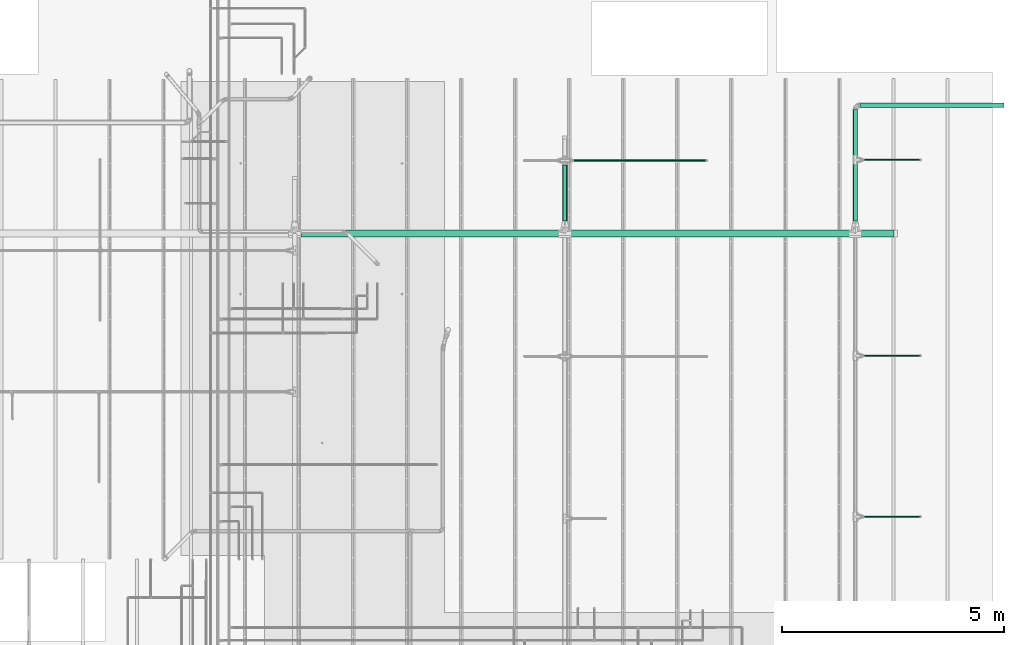
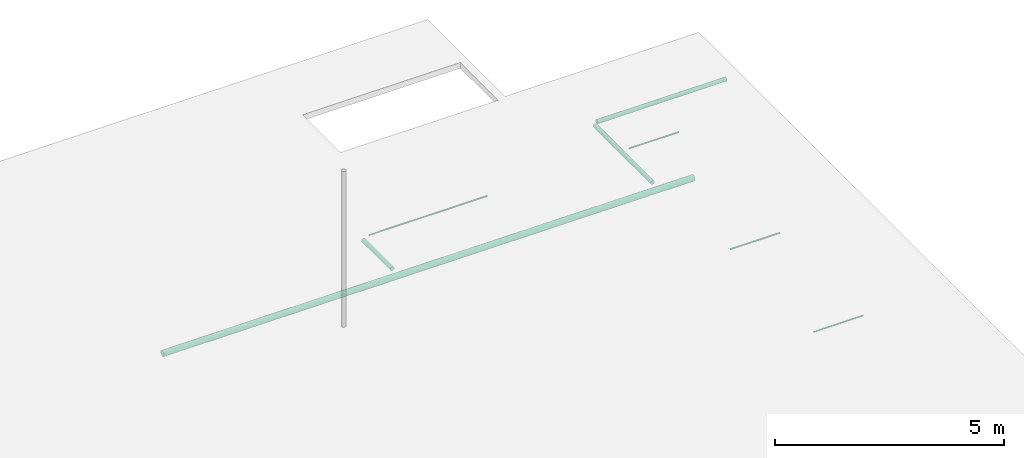
# One storey, part 7 of 173: 8 flow segments.
"""IFC2X3 building model written with IfcOpenShell, lengths in feet."""

from ifc_helpers import new_model, entity, si_unit, converted_unit, derived_unit, direction, frame, origin, origin_2d_with_axis, place, context, subcontext, project, spatial, circle, extrude, source, transform, mapped, type_object, type_shapes, element, save


model = new_model("IFC2X3")

# Units and contexts
model_context = context("Model", 3, precision=0.0001, world=origin(), true_north=direction((6.12303176911189e-17, 1.0)))
body_context = subcontext(model_context, "Body", "Model", "MODEL_VIEW")
ifc_project = project(units=[converted_unit("LENGTHUNIT", "FOOT", entity("IfcRatioMeasure", 0.3048), si_unit("LENGTHUNIT", "METRE"), dimensions=[1, 0, 0, 0, 0, 0, 0]), converted_unit("AREAUNIT", "SQUARE FOOT", entity("IfcRatioMeasure", 0.09290304), si_unit("AREAUNIT", "SQUARE_METRE"), dimensions=[2, 0, 0, 0, 0, 0, 0]), converted_unit("VOLUMEUNIT", "CUBIC FOOT", entity("IfcRatioMeasure", 0.028316846592), si_unit("VOLUMEUNIT", "CUBIC_METRE"), dimensions=[3, 0, 0, 0, 0, 0, 0]), converted_unit("PLANEANGLEUNIT", "DEGREE", entity("IfcRatioMeasure", 0.0174532925199433), si_unit("PLANEANGLEUNIT", "RADIAN"), dimensions=[0, 0, 0, 0, 0, 0, 0]), si_unit("MASSUNIT", "GRAM", prefix="KILO"), derived_unit("MASSDENSITYUNIT", [(si_unit("MASSUNIT", "GRAM", prefix="KILO"), 1), (si_unit("LENGTHUNIT", "METRE"), -3)]), si_unit("TIMEUNIT", "SECOND"), si_unit("FREQUENCYUNIT", "HERTZ"), si_unit("THERMODYNAMICTEMPERATUREUNIT", "DEGREE_CELSIUS"), derived_unit("THERMALTRANSMITTANCEUNIT", [(si_unit("MASSUNIT", "GRAM", prefix="KILO"), 1), (si_unit("THERMODYNAMICTEMPERATUREUNIT", "KELVIN"), -1), (si_unit("TIMEUNIT", "SECOND"), -3)]), derived_unit("VOLUMETRICFLOWRATEUNIT", [(si_unit("LENGTHUNIT", "METRE"), 3), (si_unit("TIMEUNIT", "SECOND"), -1)]), si_unit("ELECTRICCURRENTUNIT", "AMPERE"), si_unit("ELECTRICVOLTAGEUNIT", "VOLT"), si_unit("POWERUNIT", "WATT"), si_unit("FORCEUNIT", "NEWTON"), si_unit("ILLUMINANCEUNIT", "LUX"), si_unit("LUMINOUSFLUXUNIT", "LUMEN"), si_unit("LUMINOUSINTENSITYUNIT", "CANDELA"), derived_unit("USERDEFINED", [(si_unit("MASSUNIT", "GRAM", prefix="KILO"), -1), (si_unit("LENGTHUNIT", "METRE"), -2), (si_unit("TIMEUNIT", "SECOND"), 3), (si_unit("LUMINOUSFLUXUNIT", "LUMEN"), 1)]), derived_unit("LINEARVELOCITYUNIT", [(si_unit("LENGTHUNIT", "METRE"), 1), (si_unit("TIMEUNIT", "SECOND"), -1)]), si_unit("PRESSUREUNIT", "PASCAL"), derived_unit("USERDEFINED", [(si_unit("LENGTHUNIT", "METRE"), -2), (si_unit("MASSUNIT", "GRAM", prefix="KILO"), 1), (si_unit("TIMEUNIT", "SECOND"), -2)])], contexts=[model_context])

# Site, building, storey
site_placement = place(None, origin())
site = spatial("IfcSite", under=ifc_project, at=site_placement, CompositionType="ELEMENT")
building_placement = place(site_placement, origin())
building = spatial("IfcBuilding", under=site, at=building_placement, CompositionType="ELEMENT")
storey_placement = place(building_placement, frame((0.0, 0.0, 8.0)))
storey = spatial("IfcBuildingStorey", under=building, at=storey_placement, Name="REF", CompositionType="ELEMENT", Elevation=8.0)

# Flow segments
pipe_segment_type_1 = type_object("IfcPipeSegmentType", Name="Pipe Types:Standard", PredefinedType="NOTDEFINED")
shared_shape_1 = source(origin(), body_context, "Body", "SweptSolid", [
    extrude(circle(Radius=0.255208333333333, at=origin_2d_with_axis()), frame((3.86549075824204, 42.5032349157208, 10.4173177083333), z_axis=(1.0, 0.0, 0.0), x_axis=(0.0, -1.0, 0.0)), (0.0, 0.0, 1.0), 43.8717276472823),
])
type_shapes(pipe_segment_type_1, [shared_shape_1])
flow_segment_1_placement = place(storey_placement, frame((0.0, 0.0, -8.0)))
element("IfcFlowSegment", 1, at=flow_segment_1_placement, inside=storey, type_object=pipe_segment_type_1, Name="Pipe Types:Standard:Standard : Pipe Types:Standard", ObjectType="Standard : Pipe Types:Standard", context=body_context, shape_type="MappedRepresentation", body=[
    mapped(shared_shape_1, transform((0.0, 0.0, 0.0), scale=1.0)),
])
pipe_segment_type_2 = type_object("IfcPipeSegmentType", Name="Pipe Types:Standard", PredefinedType="NOTDEFINED")
shared_shape_2 = source(origin(), body_context, "Body", "SweptSolid", [
    extrude(circle(Radius=0.171875, at=origin_2d_with_axis()), frame((44.8963306532552, 43.4317126060094, 10.4173177083333), z_axis=(0.0, 1.0, 0.0), x_axis=(1.0, 0.0, 0.0)), (0.0, 0.0, 1.0), 8.23687664041991),
])
type_shapes(pipe_segment_type_2, [shared_shape_2])
flow_segment_2_placement = place(storey_placement, frame((0.0, 0.0, -8.0)))
element("IfcFlowSegment", 2, at=flow_segment_2_placement, inside=storey, type_object=pipe_segment_type_2, Name="Pipe Types:Standard:Standard : Pipe Types:Standard", ObjectType="Standard : Pipe Types:Standard", context=body_context, shape_type="MappedRepresentation", body=[
    mapped(shared_shape_2, transform((0.0, 0.0, 0.0), scale=1.0)),
])
pipe_segment_type_3 = type_object("IfcPipeSegmentType", Name="Pipe Types:Standard", PredefinedType="NOTDEFINED")
shared_shape_3 = source(origin(), body_context, "Body", "SweptSolid", [
    extrude(circle(Radius=0.171875, at=origin_2d_with_axis()), frame((45.2309763225465, 52.0032349157206, 10.4173177083333), z_axis=(1.0, 0.0, 0.0), x_axis=(0.0, -1.0, 0.0)), (0.0, 0.0, 1.0), 10.6653543307087),
])
type_shapes(pipe_segment_type_3, [shared_shape_3])
flow_segment_3_placement = place(storey_placement, frame((0.0, 0.0, -8.0)))
element("IfcFlowSegment", 3, at=flow_segment_3_placement, inside=storey, type_object=pipe_segment_type_3, Name="Pipe Types:Standard:Standard : Pipe Types:Standard", ObjectType="Standard : Pipe Types:Standard", context=body_context, shape_type="MappedRepresentation", body=[
    mapped(shared_shape_3, transform((0.0, 0.0, 0.0), scale=1.0)),
])
pipe_segment_type_4 = type_object("IfcPipeSegmentType", Name="Pipe Types:Standard", PredefinedType="NOTDEFINED")
shared_shape_4 = source(origin(), body_context, "Body", "SweptSolid", [
    extrude(circle(Radius=0.171875, at=origin_2d_with_axis()), frame((23.3963306532552, 43.4317126060095, 10.4173177083333), z_axis=(0.0, 1.0, 0.0), x_axis=(1.0, 0.0, 0.0)), (0.0, 0.0, 1.0), 4.13269749638239),
])
type_shapes(pipe_segment_type_4, [shared_shape_4])
flow_segment_4_placement = place(storey_placement, frame((0.0, 0.0, -8.0)))
element("IfcFlowSegment", 4, at=flow_segment_4_placement, inside=storey, type_object=pipe_segment_type_4, Name="Pipe Types:Standard:Standard : Pipe Types:Standard", ObjectType="Standard : Pipe Types:Standard", context=body_context, shape_type="MappedRepresentation", body=[
    mapped(shared_shape_4, transform((0.0, 0.0, 0.0), scale=1.0)),
])
pipe_segment_type_5 = type_object("IfcPipeSegmentType", Name="Pipe Types:Standard", PredefinedType="NOTDEFINED")
shared_shape_5 = source(origin(), body_context, "Body", "SweptSolid", [
    extrude(circle(Radius=0.046875, at=origin_2d_with_axis()), frame((24.0754645115229, 47.9088982913682, 10.4173177083333), z_axis=(1.0, 0.0, 0.0), x_axis=(0.0, -1.0, 0.0)), (0.0, 0.0, 1.0), 9.7388451443569),
])
type_shapes(pipe_segment_type_5, [shared_shape_5])
flow_segment_5_placement = place(storey_placement, frame((0.0, 0.0, -8.0)))
element("IfcFlowSegment", 5, at=flow_segment_5_placement, inside=storey, type_object=pipe_segment_type_5, Name="Pipe Types:Standard:Standard : Pipe Types:Standard", ObjectType="Standard : Pipe Types:Standard", context=body_context, shape_type="MappedRepresentation", body=[
    mapped(shared_shape_5, transform((0.0, 0.0, 0.0), scale=1.0)),
])
pipe_segment_type_6 = type_object("IfcPipeSegmentType", Name="Pipe Types:Standard", PredefinedType="NOTDEFINED")
shared_shape_6 = source(origin(), body_context, "Body", "SweptSolid", [
    extrude(circle(Radius=0.046875, at=origin_2d_with_axis()), frame((45.5754645115229, 47.9591871568718, 10.4173177083333), z_axis=(1.0, 0.0, 0.0), x_axis=(0.0, -1.0, 0.0)), (0.0, 0.0, 1.0), 4.07217847769013),
])
type_shapes(pipe_segment_type_6, [shared_shape_6])
flow_segment_6_placement = place(storey_placement, frame((0.0, 0.0, -8.0)))
element("IfcFlowSegment", 6, at=flow_segment_6_placement, inside=storey, type_object=pipe_segment_type_6, Name="Pipe Types:Standard:Standard : Pipe Types:Standard", ObjectType="Standard : Pipe Types:Standard", context=body_context, shape_type="MappedRepresentation", body=[
    mapped(shared_shape_6, transform((0.0, 0.0, 0.0), scale=1.0)),
])
pipe_segment_type_7 = type_object("IfcPipeSegmentType", Name="Pipe Types:Standard", PredefinedType="NOTDEFINED")
shared_shape_7 = source(origin(), body_context, "Body", "SweptSolid", [
    extrude(circle(Radius=0.046875, at=origin_2d_with_axis()), frame((45.5754645115229, 33.4591871568718, 10.4173177083333), z_axis=(1.0, 0.0, 0.0), x_axis=(0.0, -1.0, 0.0)), (0.0, 0.0, 1.0), 4.07217847769013),
])
type_shapes(pipe_segment_type_7, [shared_shape_7])
flow_segment_7_placement = place(storey_placement, frame((0.0, 0.0, -8.0)))
element("IfcFlowSegment", 7, at=flow_segment_7_placement, inside=storey, type_object=pipe_segment_type_7, Name="Pipe Types:Standard:Standard : Pipe Types:Standard", ObjectType="Standard : Pipe Types:Standard", context=body_context, shape_type="MappedRepresentation", body=[
    mapped(shared_shape_7, transform((0.0, 0.0, 0.0), scale=1.0)),
])
pipe_segment_type_8 = type_object("IfcPipeSegmentType", Name="Pipe Types:Standard", PredefinedType="NOTDEFINED")
shared_shape_8 = source(origin(), body_context, "Body", "SweptSolid", [
    extrude(circle(Radius=0.046875, at=origin_2d_with_axis()), frame((45.5754645115229, 21.5425204902052, 10.4173177083333), z_axis=(1.0, 0.0, 0.0), x_axis=(0.0, -1.0, 0.0)), (0.0, 0.0, 1.0), 4.07217847769013),
])
type_shapes(pipe_segment_type_8, [shared_shape_8])
flow_segment_8_placement = place(storey_placement, frame((0.0, 0.0, -8.0)))
element("IfcFlowSegment", 8, at=flow_segment_8_placement, inside=storey, type_object=pipe_segment_type_8, Name="Pipe Types:Standard:Standard : Pipe Types:Standard", ObjectType="Standard : Pipe Types:Standard", context=body_context, shape_type="MappedRepresentation", body=[
    mapped(shared_shape_8, transform((0.0, 0.0, 0.0), scale=1.0)),
])

save(model, "model.ifc")
